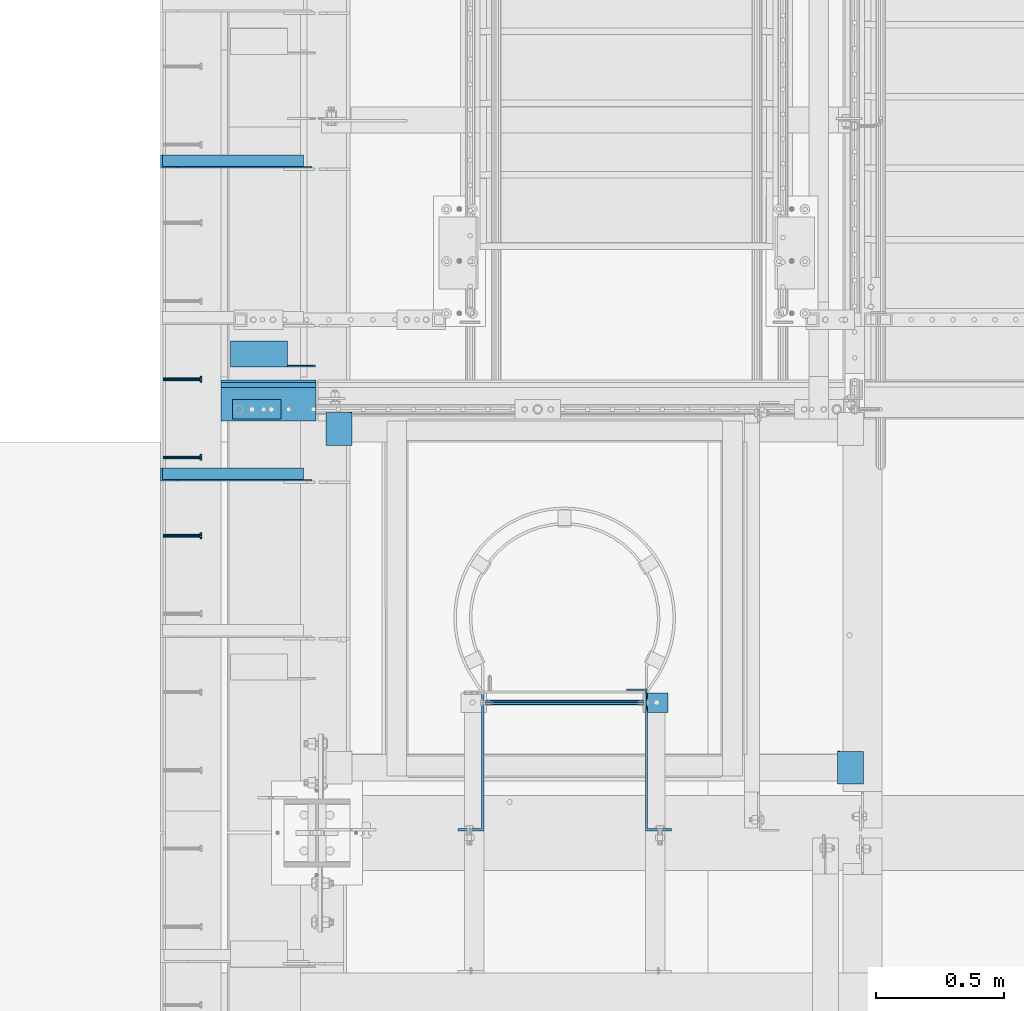
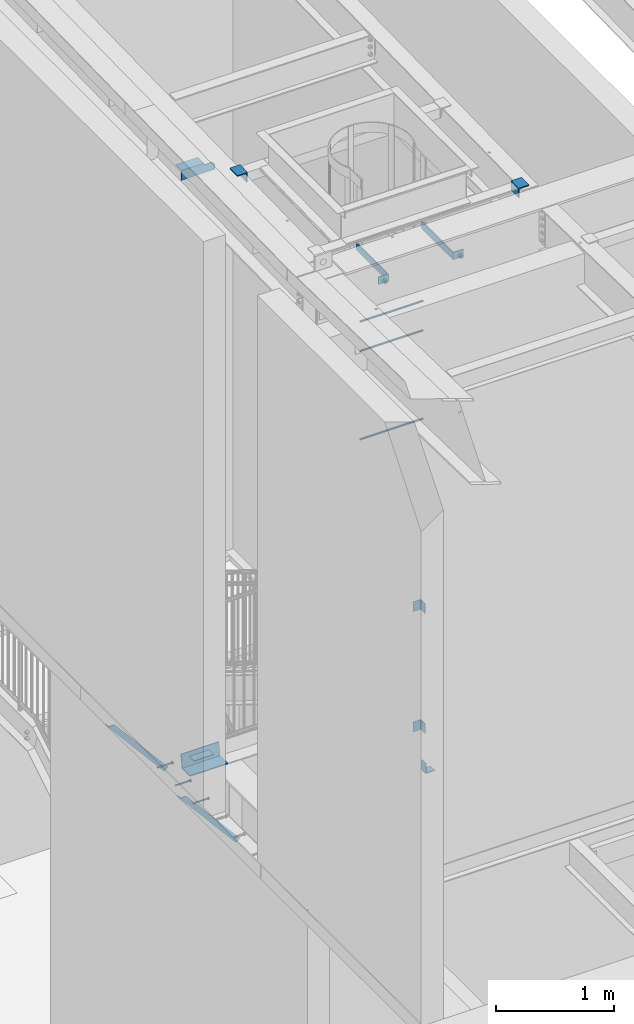
# One storey, part 1256 of 1763: 16 beams, 2 members, 8 elements without a shape of their own.
"""IFC2X3 building model written with IfcOpenShell, lengths in millimetres."""

from ifc_helpers import new_model, si_unit, frame, origin_with_axes, place, context, subcontext, project, spatial, faceted_brep, material, type_object, element, aggregate, save


model = new_model("IFC2X3")

# Units and contexts
model_context = context("Model", 3, precision=1e-05, world=origin_with_axes())
body_context = subcontext(model_context, "Body", "Model", "MODEL_VIEW")
ifc_project = project(units=[si_unit("LENGTHUNIT", "METRE", prefix="MILLI"), si_unit("AREAUNIT", "SQUARE_METRE"), si_unit("VOLUMEUNIT", "CUBIC_METRE"), si_unit("MASSUNIT", "GRAM", prefix="KILO"), si_unit("TIMEUNIT", "SECOND"), si_unit("PLANEANGLEUNIT", "RADIAN"), si_unit("SOLIDANGLEUNIT", "STERADIAN"), si_unit("THERMODYNAMICTEMPERATUREUNIT", "DEGREE_CELSIUS"), si_unit("LUMINOUSINTENSITYUNIT", "LUMEN")], contexts=[model_context])

# Site, building, storey
site_placement = place(None, origin_with_axes())
site = spatial("IfcSite", under=ifc_project, at=site_placement, CompositionType="ELEMENT")
building_placement = place(site_placement, origin_with_axes())
building = spatial("IfcBuilding", under=site, at=building_placement, Name="Undefined", CompositionType="ELEMENT")
storey_placement = place(building_placement, origin_with_axes())
storey = spatial("IfcBuildingStorey", under=building, at=storey_placement, Name="Undefined", CompositionType="ELEMENT", Elevation=0.0)

# Assembly, beam
assembly_1_placement = place(storey_placement, origin_with_axes())
assembly_1 = element("IfcElementAssembly", 1, at=assembly_1_placement, inside=storey, Name="HEADED STUD ANCHOR", AssemblyPlace="NOTDEFINED", PredefinedType="RIGID_FRAME")
ifc_material_1 = material(Name="STEEL/A108")
beam_type_1 = type_object("IfcBeamType", PredefinedType="NOTDEFINED")
beam_1_placement = place(assembly_1_placement, frame((-87975.5122736983, 31181.6750061035, 5268.91250001202), z_axis=(0.0, 0.0, -1.0), x_axis=(1.0, 0.0, 0.0)))
beam_1 = element("IfcBeam", 2, at=beam_1_placement, type_object=beam_type_1, material=ifc_material_1, Name="HEADED STUD ANCHOR", context=body_context, shape_type="Brep", body=[
    faceted_brep([(0.0, -3.1800000667572, 5.5), (0.0, -5.5, 3.1800000667572), (141.732000000002, -5.5, 3.1800000667572), (141.732000000002, -3.1800000667572, 5.5), (0.0, -6.34999999999491, 1.45519152283669e-11), (141.732000000002, -6.34999990463257, 0.0), (0.0, -5.5, -3.1800000667572), (141.732000000002, -5.5, -3.1800000667572), (0.0, -3.1800000667572, -5.5), (141.732000000002, -3.1800000667572, -5.5), (0.0, 0.0, -6.34999990463257), (141.732000000002, 0.0, -6.34999990463257), (0.0, 3.1800000667572, -5.5), (141.732000000002, 3.1800000667572, -5.5), (0.0, 5.5, -3.1800000667572), (141.732000000002, 5.5, -3.1800000667572), (0.0, 6.34999999999491, -2.91038304567337e-11), (141.732000000002, 6.34999990463257, 0.0), (0.0, 5.5, 3.1800000667572), (141.732000000002, 5.5, 3.1800000667572), (0.0, 3.1800000667572, 5.5), (141.732000000002, 3.1800000667572, 5.5), (0.0, 0.0, 6.34999990463257), (141.732000000002, 0.0, 6.34999990463257), (144.780000000001, -10.9899997711182, 6.34999990463257), (144.780000000001, -6.34000015258789, 10.9899997711182), (144.780000000001, -12.6999998092651, 0.0), (144.780000000001, -10.9899997711182, -6.34999990463257), (144.780000000001, -6.34000015258789, -10.9899997711182), (144.780000000001, 0.0, -12.6899995803833), (144.780000000001, 6.34000015258789, -10.9899997711182), (144.780000000001, 10.9899997711182, -6.34999990463257), (144.780000000001, 12.6999998092651, 0.0), (144.780000000001, 10.9899997711182, 6.34999990463257), (144.780000000001, 6.34000015258789, 10.9899997711182), (144.780000000001, 0.0, 12.6899995803833), (152.400000000001, -10.9899997711182, 6.34999990463257), (152.400000000001, -6.34000015258789, 10.9899997711182), (152.400000000001, -12.6999998092651, 0.0), (152.400000000001, -10.9899997711182, -6.34999990463257), (152.400000000001, -6.34000015258789, -10.9899997711182), (152.400000000001, 0.0, -12.6899995803833), (152.400000000001, 6.34000015258789, -10.9899997711182), (152.400000000001, 10.9899997711182, -6.34999990463257), (152.400000000001, 12.6999998092651, 0.0), (152.400000000001, 10.9899997711182, 6.34999990463257), (152.400000000001, 6.34000015258789, 10.9899997711182), (152.400000000001, 0.0, 12.6899995803833)], [[[0, 1, 2, 3]], [[1, 4, 5, 2]], [[4, 6, 7, 5]], [[6, 8, 9, 7]], [[8, 10, 11, 9]], [[10, 12, 13, 11]], [[12, 14, 15, 13]], [[14, 16, 17, 15]], [[16, 18, 19, 17]], [[18, 20, 21, 19]], [[20, 22, 23, 21]], [[22, 0, 3, 23]], [[22, 20, 18, 16, 14, 12, 10, 8, 6, 4, 1, 0]], [[3, 2, 24, 25]], [[2, 5, 26, 24]], [[5, 7, 27, 26]], [[7, 9, 28, 27]], [[9, 11, 29, 28]], [[11, 13, 30, 29]], [[13, 15, 31, 30]], [[15, 17, 32, 31]], [[17, 19, 33, 32]], [[19, 21, 34, 33]], [[21, 23, 35, 34]], [[23, 3, 25, 35]], [[25, 24, 36, 37]], [[24, 26, 38, 36]], [[26, 27, 39, 38]], [[27, 28, 40, 39]], [[28, 29, 41, 40]], [[29, 30, 42, 41]], [[30, 31, 43, 42]], [[31, 32, 44, 43]], [[32, 33, 45, 44]], [[33, 34, 46, 45]], [[34, 35, 47, 46]], [[35, 25, 37, 47]], [[38, 39, 40, 41, 42, 43, 44, 45, 46, 47, 37, 36]]]),
])
aggregate(assembly_1, [beam_1])

assembly_2_placement = place(storey_placement, origin_with_axes())
assembly_2 = element("IfcElementAssembly", 3, at=assembly_2_placement, inside=storey, Name="HEADED STUD ANCHOR", AssemblyPlace="NOTDEFINED", PredefinedType="RIGID_FRAME")
beam_2_placement = place(assembly_2_placement, frame((-87975.5122736983, 31486.4750061035, 5268.91250001202), z_axis=(0.0, 0.0, -1.0), x_axis=(1.0, 0.0, 0.0)))
beam_2 = element("IfcBeam", 4, at=beam_2_placement, type_object=beam_type_1, material=ifc_material_1, Name="HEADED STUD ANCHOR", context=body_context, shape_type="Brep", body=[
    faceted_brep([(0.0, -3.1800000667572, 5.5), (0.0, -5.5, 3.1800000667572), (141.732000000002, -5.5, 3.1800000667572), (141.732000000002, -3.1800000667572, 5.5), (0.0, -6.34999999999491, 1.45519152283669e-11), (141.732000000002, -6.34999990463257, 0.0), (0.0, -5.5, -3.1800000667572), (141.732000000002, -5.5, -3.1800000667572), (0.0, -3.1800000667572, -5.5), (141.732000000002, -3.1800000667572, -5.5), (0.0, 0.0, -6.34999990463257), (141.732000000002, 0.0, -6.34999990463257), (0.0, 3.1800000667572, -5.5), (141.732000000002, 3.1800000667572, -5.5), (0.0, 5.5, -3.1800000667572), (141.732000000002, 5.5, -3.1800000667572), (0.0, 6.34999999999491, -2.91038304567337e-11), (141.732000000002, 6.34999990463257, 0.0), (0.0, 5.5, 3.1800000667572), (141.732000000002, 5.5, 3.1800000667572), (0.0, 3.1800000667572, 5.5), (141.732000000002, 3.1800000667572, 5.5), (0.0, 0.0, 6.34999990463257), (141.732000000002, 0.0, 6.34999990463257), (144.780000000001, -10.9899997711182, 6.34999990463257), (144.780000000001, -6.34000015258789, 10.9899997711182), (144.780000000001, -12.6999998092651, 0.0), (144.780000000001, -10.9899997711182, -6.34999990463257), (144.780000000001, -6.34000015258789, -10.9899997711182), (144.780000000001, 0.0, -12.6899995803833), (144.780000000001, 6.34000015258789, -10.9899997711182), (144.780000000001, 10.9899997711182, -6.34999990463257), (144.780000000001, 12.6999998092651, 0.0), (144.780000000001, 10.9899997711182, 6.34999990463257), (144.780000000001, 6.34000015258789, 10.9899997711182), (144.780000000001, 0.0, 12.6899995803833), (152.400000000001, -10.9899997711182, 6.34999990463257), (152.400000000001, -6.34000015258789, 10.9899997711182), (152.400000000001, -12.6999998092651, 0.0), (152.400000000001, -10.9899997711182, -6.34999990463257), (152.400000000001, -6.34000015258789, -10.9899997711182), (152.400000000001, 0.0, -12.6899995803833), (152.400000000001, 6.34000015258789, -10.9899997711182), (152.400000000001, 10.9899997711182, -6.34999990463257), (152.400000000001, 12.6999998092651, 0.0), (152.400000000001, 10.9899997711182, 6.34999990463257), (152.400000000001, 6.34000015258789, 10.9899997711182), (152.400000000001, 0.0, 12.6899995803833)], [[[0, 1, 2, 3]], [[1, 4, 5, 2]], [[4, 6, 7, 5]], [[6, 8, 9, 7]], [[8, 10, 11, 9]], [[10, 12, 13, 11]], [[12, 14, 15, 13]], [[14, 16, 17, 15]], [[16, 18, 19, 17]], [[18, 20, 21, 19]], [[20, 22, 23, 21]], [[22, 0, 3, 23]], [[22, 20, 18, 16, 14, 12, 10, 8, 6, 4, 1, 0]], [[3, 2, 24, 25]], [[2, 5, 26, 24]], [[5, 7, 27, 26]], [[7, 9, 28, 27]], [[9, 11, 29, 28]], [[11, 13, 30, 29]], [[13, 15, 31, 30]], [[15, 17, 32, 31]], [[17, 19, 33, 32]], [[19, 21, 34, 33]], [[21, 23, 35, 34]], [[23, 3, 25, 35]], [[25, 24, 36, 37]], [[24, 26, 38, 36]], [[26, 27, 39, 38]], [[27, 28, 40, 39]], [[28, 29, 41, 40]], [[29, 30, 42, 41]], [[30, 31, 43, 42]], [[31, 32, 44, 43]], [[32, 33, 45, 44]], [[33, 34, 46, 45]], [[34, 35, 47, 46]], [[35, 25, 37, 47]], [[38, 39, 40, 41, 42, 43, 44, 45, 46, 47, 37, 36]]]),
])
aggregate(assembly_2, [beam_2])

assembly_3_placement = place(storey_placement, origin_with_axes())
assembly_3 = element("IfcElementAssembly", 5, at=assembly_3_placement, inside=storey, Name="HEADED STUD ANCHOR", AssemblyPlace="NOTDEFINED", PredefinedType="RIGID_FRAME")
beam_3_placement = place(assembly_3_placement, frame((-87975.5122736983, 31791.2750061035, 5268.91250001202), z_axis=(0.0, 0.0, -1.0), x_axis=(1.0, 0.0, 0.0)))
beam_3 = element("IfcBeam", 6, at=beam_3_placement, type_object=beam_type_1, material=ifc_material_1, Name="HEADED STUD ANCHOR", context=body_context, shape_type="Brep", body=[
    faceted_brep([(0.0, -3.1800000667572, 5.5), (0.0, -5.5, 3.1800000667572), (141.732000000002, -5.5, 3.1800000667572), (141.732000000002, -3.1800000667572, 5.5), (0.0, -6.34999999999491, 1.45519152283669e-11), (141.732000000002, -6.34999990463257, 0.0), (0.0, -5.5, -3.1800000667572), (141.732000000002, -5.5, -3.1800000667572), (0.0, -3.1800000667572, -5.5), (141.732000000002, -3.1800000667572, -5.5), (0.0, 0.0, -6.34999990463257), (141.732000000002, 0.0, -6.34999990463257), (0.0, 3.1800000667572, -5.5), (141.732000000002, 3.1800000667572, -5.5), (0.0, 5.5, -3.1800000667572), (141.732000000002, 5.5, -3.1800000667572), (0.0, 6.34999999999491, -2.91038304567337e-11), (141.732000000002, 6.34999990463257, 0.0), (0.0, 5.5, 3.1800000667572), (141.732000000002, 5.5, 3.1800000667572), (0.0, 3.1800000667572, 5.5), (141.732000000002, 3.1800000667572, 5.5), (0.0, 0.0, 6.34999990463257), (141.732000000002, 0.0, 6.34999990463257), (144.780000000001, -10.9899997711182, 6.34999990463257), (144.780000000001, -6.34000015258789, 10.9899997711182), (144.780000000001, -12.6999998092651, 0.0), (144.780000000001, -10.9899997711182, -6.34999990463257), (144.780000000001, -6.34000015258789, -10.9899997711182), (144.780000000001, 0.0, -12.6899995803833), (144.780000000001, 6.34000015258789, -10.9899997711182), (144.780000000001, 10.9899997711182, -6.34999990463257), (144.780000000001, 12.6999998092651, 0.0), (144.780000000001, 10.9899997711182, 6.34999990463257), (144.780000000001, 6.34000015258789, 10.9899997711182), (144.780000000001, 0.0, 12.6899995803833), (152.400000000001, -10.9899997711182, 6.34999990463257), (152.400000000001, -6.34000015258789, 10.9899997711182), (152.400000000001, -12.6999998092651, 0.0), (152.400000000001, -10.9899997711182, -6.34999990463257), (152.400000000001, -6.34000015258789, -10.9899997711182), (152.400000000001, 0.0, -12.6899995803833), (152.400000000001, 6.34000015258789, -10.9899997711182), (152.400000000001, 10.9899997711182, -6.34999990463257), (152.400000000001, 12.6999998092651, 0.0), (152.400000000001, 10.9899997711182, 6.34999990463257), (152.400000000001, 6.34000015258789, 10.9899997711182), (152.400000000001, 0.0, 12.6899995803833)], [[[0, 1, 2, 3]], [[1, 4, 5, 2]], [[4, 6, 7, 5]], [[6, 8, 9, 7]], [[8, 10, 11, 9]], [[10, 12, 13, 11]], [[12, 14, 15, 13]], [[14, 16, 17, 15]], [[16, 18, 19, 17]], [[18, 20, 21, 19]], [[20, 22, 23, 21]], [[22, 0, 3, 23]], [[22, 20, 18, 16, 14, 12, 10, 8, 6, 4, 1, 0]], [[3, 2, 24, 25]], [[2, 5, 26, 24]], [[5, 7, 27, 26]], [[7, 9, 28, 27]], [[9, 11, 29, 28]], [[11, 13, 30, 29]], [[13, 15, 31, 30]], [[15, 17, 32, 31]], [[17, 19, 33, 32]], [[19, 21, 34, 33]], [[21, 23, 35, 34]], [[23, 3, 25, 35]], [[25, 24, 36, 37]], [[24, 26, 38, 36]], [[26, 27, 39, 38]], [[27, 28, 40, 39]], [[28, 29, 41, 40]], [[29, 30, 42, 41]], [[30, 31, 43, 42]], [[31, 32, 44, 43]], [[32, 33, 45, 44]], [[33, 34, 46, 45]], [[34, 35, 47, 46]], [[35, 25, 37, 47]], [[38, 39, 40, 41, 42, 43, 44, 45, 46, 47, 37, 36]]]),
])
aggregate(assembly_3, [beam_3])

# Assembly, members
assembly_4_placement = place(storey_placement, origin_with_axes())
assembly_4 = element("IfcElementAssembly", 7, at=assembly_4_placement, inside=storey, Name="BEAM", AssemblyPlace="NOTDEFINED", PredefinedType="RIGID_FRAME")
ifc_material_2 = material(Name="STEEL/A36")
member_type = type_object("IfcMemberType", Name="L2X2X1/4", PredefinedType="NOTDEFINED")
member_1_placement = place(assembly_4_placement, frame((-87414.1929584935, 32639.0, 4557.35349338836), z_axis=(0.764183480307171, 0.0, 0.644998921259268), x_axis=(-0.644998921259266, 0.0, 0.764183480307173)))
member_1 = element("IfcMember", 8, at=member_1_placement, type_object=member_type, material=ifc_material_2, Name="ANGLE", ObjectType="L2X2X1/4", context=body_context, shape_type="Brep", body=[
    faceted_brep([(-1.45519152283669e-11, 25.4000000000015, -25.3999999999869), (1.45519152283669e-11, 25.4000000000015, 25.3999999999796), (812.060911532491, 25.4000000000015, 25.400000001966), (854.937976763787, 25.4000000000015, -25.3999999979424), (1.45519152283669e-11, 19.0499999999993, 25.3999999999796), (812.060911532491, 19.0500000000029, 25.400000001966), (-7.27595761418343e-12, 19.0499999999993, -19.0499999999956), (849.578343609872, 19.0500000000029, -19.0499999979511), (-7.27595761418343e-12, -25.4000000000015, -19.0499999999956), (849.578343609872, -25.4000000000015, -19.0499999979511), (-1.45519152283669e-11, -25.4000000000015, -25.3999999999869), (854.937976763787, -25.4000000000015, -25.3999999979424)], [[[0, 1, 2, 3]], [[1, 4, 5, 2]], [[4, 6, 7, 5]], [[6, 8, 9, 7]], [[8, 10, 11, 9]], [[10, 0, 3, 11]], [[5, 7, 9, 11, 3, 2]], [[10, 8, 6, 4, 1, 0]]]),
])
member_2_placement = place(assembly_4_placement, frame((-87414.1929584935, 31419.8, 4557.35349338836), z_axis=(0.764183480307171, 0.0, 0.644998921259268), x_axis=(-0.644998921259266, 0.0, 0.764183480307173)))
member_2 = element("IfcMember", 9, at=member_2_placement, type_object=member_type, material=ifc_material_2, Name="ANGLE", ObjectType="L2X2X1/4", context=body_context, shape_type="Brep", body=[
    faceted_brep([(-1.45519152283669e-11, 25.4000000000015, -25.3999999999869), (1.45519152283669e-11, 25.4000000000015, 25.3999999999796), (812.060911532491, 25.4000000000015, 25.400000001966), (854.937976763787, 25.4000000000015, -25.3999999979424), (1.45519152283669e-11, 19.0499999999993, 25.3999999999796), (812.060911532491, 19.0500000000029, 25.400000001966), (-7.27595761418343e-12, 19.0499999999993, -19.0499999999956), (849.578343609872, 19.0500000000029, -19.0499999979511), (-7.27595761418343e-12, -25.4000000000015, -19.0499999999956), (849.578343609872, -25.4000000000015, -19.0499999979511), (-1.45519152283669e-11, -25.4000000000015, -25.3999999999869), (854.937976763787, -25.4000000000015, -25.3999999979424)], [[[0, 1, 2, 3]], [[1, 4, 5, 2]], [[4, 6, 7, 5]], [[6, 8, 9, 7]], [[8, 10, 11, 9]], [[10, 0, 3, 11]], [[5, 7, 9, 11, 3, 2]], [[10, 8, 6, 4, 1, 0]]]),
])

# Assembly, beam
assembly_5_placement = place(storey_placement, origin_with_axes())
assembly_5 = element("IfcElementAssembly", 10, at=assembly_5_placement, inside=storey, Name="BEAM", AssemblyPlace="NOTDEFINED", PredefinedType="RIGID_FRAME")
beam_type_2 = type_object("IfcBeamType", Name="L4X4X1/4", PredefinedType="NOTDEFINED")
beam_4_placement = place(assembly_5_placement, frame((-87711.9872706466, 31890.376306879, 11278.1286374879), z_axis=(0.0, 0.0206852279954837, -0.999786037781472), x_axis=(1.0, 0.0, 0.0)))
beam_4 = element("IfcBeam", 11, at=beam_4_placement, type_object=beam_type_2, material=ifc_material_2, Name="BRACE", ObjectType="L4X4X1/4", context=body_context, shape_type="Brep", body=[
    faceted_brep([(220.662761923406, 44.4500000001208, -44.4499999999807), (220.662761962012, -50.800000000163, -44.4499999999553), (220.66276795695, -50.800000000163, -50.7999999999502), (220.662767915564, 50.8000000001339, -50.7999999999774), (220.662751535681, 50.8000000001339, -33.3786578752915), (220.662751538272, 44.4500000001208, -33.3786578752897), (299.243730570859, 44.4500000001135, -33.3375021376705), (299.243730570859, 50.8000000001339, -33.3375021376723), (2.11002770811319e-10, -50.8000000000357, -50.799999999952), (1.96450855582952e-10, -50.8000000000338, -44.4499999999534), (-2.18278728425503e-11, 44.4500000000007, -44.450000000048), (-1.81898940354586e-10, 44.4500000000371, 50.7999999999374), (-1.96450855582952e-10, 50.8000000000393, 50.7999999999374), (-3.63797880709171e-11, 50.8000000000011, -50.8000000000538), (330.993731689443, 44.4500000000007, 50.7999999999993), (330.993731689443, 50.7999999999993, 50.7999999999993), (330.993730570859, 44.4500000001281, -1.58750213774329), (330.993746948254, 50.8000000001412, -1.5875021377451)], [[[0, 1, 2, 3, 4, 5]], [[6, 5, 4, 7]], [[8, 9, 10, 11, 12, 13]], [[12, 11, 14, 15]], [[15, 14, 16, 17]], [[17, 16, 6, 7]], [[3, 13, 12, 15, 17, 7, 4]], [[8, 13, 3, 2]], [[9, 8, 2, 1]], [[10, 9, 1, 0]], [[16, 14, 11, 10, 0, 5, 6]]]),
])
aggregate(assembly_5, [beam_4])

# Assembly, beams
assembly_6_placement = place(storey_placement, origin_with_axes())
assembly_6 = element("IfcElementAssembly", 12, at=assembly_6_placement, inside=storey, Name="ANGLE", AssemblyPlace="NOTDEFINED", PredefinedType="RIGID_FRAME")
beam_type_3 = type_object("IfcBeamType", Name="L4X4X3/8", PredefinedType="NOTDEFINED")
beam_5_placement = place(assembly_6_placement, frame((-85296.5734375, 30341.7077508276, 11255.2535212873), z_axis=(0.0, 0.0209829029927459, -0.999779834654609), x_axis=(0.0, -0.999779834654609, -0.0209829029927513)))
beam_5 = element("IfcBeam", 13, at=beam_5_placement, type_object=beam_type_3, material=ifc_material_2, Name="ANGLE", ObjectType="L4X4X3/8", context=body_context, shape_type="Brep", body=[
    faceted_brep([(-3.63797880709171e-11, 50.8000000000011, -50.8000000000538), (-1.96450855582952e-10, 50.8000000000393, 50.7999999999374), (127.680357143057, 50.8000000000029, 50.8000000000775), (127.680357142966, 50.8000000000029, -50.7999999998556), (0.0, 41.2749999999996, 50.7999999999993), (127.680357143057, 41.2749999999942, 50.8000000000775), (0.0, 41.2749999999996, -41.2750000000015), (127.680357142981, 41.2749999999942, -41.2749999998596), (0.0, -50.7999999999993, -41.2750000000015), (127.680357142981, -50.8000000000029, -41.2749999998596), (2.11002770811319e-10, -50.8000000000357, -50.799999999952), (127.680357142966, -50.8000000000029, -50.7999999998556)], [[[0, 1, 2, 3]], [[1, 4, 5, 2]], [[4, 6, 7, 5]], [[6, 8, 9, 7]], [[8, 10, 11, 9]], [[10, 0, 3, 11]], [[5, 7, 9, 11, 3, 2]], [[10, 8, 6, 4, 1, 0]]]),
])
beam_6_placement = place(assembly_6_placement, frame((-87289.6796875, 31534.5647100958, 11280.2886345726), z_axis=(0.0, 0.0209829029927459, -0.999779834654609), x_axis=(0.0, 0.999779834654609, 0.0209829029927513)))
beam_6 = element("IfcBeam", 14, at=beam_6_placement, type_object=beam_type_3, material=ifc_material_2, Name="ANGLE", ObjectType="L4X4X3/8", context=body_context, shape_type="Brep", body=[
    faceted_brep([(-3.63797880709171e-11, 50.8000000000011, -50.8000000000538), (-1.96450855582952e-10, 50.8000000000393, 50.7999999999374), (127.680357143057, 50.8000000000029, 50.8000000000775), (127.680357142966, 50.8000000000029, -50.7999999998556), (0.0, 41.2749999999996, 50.7999999999993), (127.680357143057, 41.2749999999942, 50.8000000000775), (0.0, 41.2749999999996, -41.2750000000015), (127.680357142981, 41.2749999999942, -41.2749999998596), (0.0, -50.7999999999993, -41.2750000000015), (127.680357142981, -50.8000000000029, -41.2749999998596), (2.11002770811319e-10, -50.8000000000357, -50.799999999952), (127.680357142966, -50.8000000000029, -50.7999999998556)], [[[0, 1, 2, 3]], [[1, 4, 5, 2]], [[4, 6, 7, 5]], [[6, 8, 9, 7]], [[8, 10, 11, 9]], [[10, 0, 3, 11]], [[5, 7, 9, 11, 3, 2]], [[10, 8, 6, 4, 1, 0]]]),
])
aggregate(assembly_6, [beam_5, beam_6])

# Assembly, beam
assembly_7_placement = place(storey_placement, origin_with_axes())
assembly_7 = element("IfcElementAssembly", 15, at=assembly_7_placement, inside=storey, Name="LADDER", AssemblyPlace="NOTDEFINED", PredefinedType="RIGID_FRAME")
beam_type_4 = type_object("IfcBeamType", PredefinedType="NOTDEFINED")
beam_7_placement = place(assembly_7_placement, frame((-86006.9472948628, 30530.7999938243, 5337.17499999941), z_axis=(0.0, 1.0, 0.0), x_axis=(-1.0, 0.0, 0.0)))
beam_7 = element("IfcBeam", 16, at=beam_7_placement, type_object=beam_type_4, material=ifc_material_2, Name="BENT_PLATE", context=body_context, shape_type="Brep", body=[
    faceted_brep([(0.0, -3.17500000000018, -38.0999999999985), (0.0, -3.17500000000018, 38.0999999999985), (0.0, 3.17500000000018, 38.0999999999985), (0.0, 3.17500000000018, -38.0999999999985), (82.5500015258731, 3.17500000000655, 38.0999999999985), (82.5500015258731, 3.17500000000655, -38.0999999999985), (88.9000015258789, -3.17499999999291, -38.0999999999985), (88.9000015258789, -3.17499999999291, 38.0999999999985), (82.5500015258731, 98.4249984741209, 38.0999999999985), (82.5500015258731, 98.4249984741209, -38.0999999999985), (88.9000015258789, 98.4249984741209, 38.0999999999985), (88.9000015258789, 98.4249984741209, -38.0999999999985)], [[[0, 1, 2, 3]], [[3, 2, 4, 5]], [[1, 0, 6, 7]], [[5, 4, 8, 9]], [[4, 2, 1, 7, 10, 8]], [[7, 6, 11, 10]], [[6, 0, 3, 5, 9, 11]], [[10, 11, 9, 8]]]),
])

assembly_8_placement = place(storey_placement, origin_with_axes())
assembly_8 = element("IfcElementAssembly", 17, at=assembly_8_placement, inside=storey, Name="RAIL", AssemblyPlace="NOTDEFINED", PredefinedType="RIGID_FRAME")
beam_8_placement = place(assembly_8_placement, frame((-87610.3872736986, 31635.699999617, 5337.175), z_axis=(-1.0, 0.0, 0.0), x_axis=(0.0, 1.0, 0.0)))
beam_8 = element("IfcBeam", 18, at=beam_8_placement, type_object=beam_type_4, material=ifc_material_2, context=body_context, shape_type="Brep", body=[
    faceted_brep([(0.0, 3.17500000000001, -95.25), (0.0, 3.17499999999927, 95.25), (76.1999968561649, 3.17499999984284, 95.25), (76.1999999999971, 3.17500000000001, -95.25), (0.0, -3.17499999999927, 95.25), (76.1999970403122, -3.17500000015571, 95.25), (0.0, -3.17500000000001, -95.25), (76.1999999999971, -3.17500000000001, -95.25)], [[[0, 1, 2, 3]], [[1, 4, 5, 2]], [[4, 6, 7, 5]], [[6, 0, 3, 7]], [[5, 7, 3, 2]], [[6, 4, 1, 0]]]),
])
aggregate(assembly_8, [beam_8])

# Beam
beam_type_5 = type_object("IfcBeamType", PredefinedType="NOTDEFINED")
beam_9_placement = place(assembly_7_placement, frame((-86100.6747736991, 30530.8, 8991.6), z_axis=(0.0, -1.0, 0.0), x_axis=(-1.0, 0.0, 0.0)))
beam_9 = element("IfcBeam", 19, at=beam_9_placement, type_object=beam_type_5, material=ifc_material_2, Name="RUNG", context=body_context, shape_type="Brep", body=[
    faceted_brep([(0.0, -9.52500000000146, 0.0), (0.0, -6.73519209080041, -6.73519209079677), (619.125, -6.73519209080223, -6.73519209080041), (619.125, -9.52499999999964, 0.0), (0.0, 0.0, -9.52499999999418), (619.125, 0.0, -9.52500000000146), (0.0, 6.73519209080041, -6.73519209079677), (619.125, 6.73519209080223, -6.73519209080041), (0.0, 9.52500000000146, 0.0), (619.125, 9.52499999999964, 0.0), (0.0, 6.73519209080041, 6.73519209079677), (619.125, 6.73519209080223, 6.73519209080041), (0.0, 0.0, 9.52499999999418), (619.125, 0.0, 9.52500000000146), (0.0, -6.73519209080041, 6.73519209079677), (619.125, -6.73519209080223, 6.73519209080041)], [[[0, 1, 2, 3]], [[1, 4, 5, 2]], [[4, 6, 7, 5]], [[6, 8, 9, 7]], [[8, 10, 11, 9]], [[10, 12, 13, 11]], [[12, 14, 15, 13]], [[14, 0, 3, 15]], [[5, 7, 9, 11, 13, 15, 3, 2]], [[14, 12, 10, 8, 6, 4, 1, 0]]]),
])

beam_10_placement = place(assembly_7_placement, frame((-86100.6747736991, 30530.8, 9906.0), z_axis=(0.0, -1.0, 0.0), x_axis=(-1.0, 0.0, 0.0)))
beam_10 = element("IfcBeam", 20, at=beam_10_placement, type_object=beam_type_5, material=ifc_material_2, Name="RUNG", context=body_context, shape_type="Brep", body=[
    faceted_brep([(0.0, -9.52500000000146, 0.0), (0.0, -6.73519209080041, -6.73519209079677), (619.125, -6.73519209080223, -6.73519209080041), (619.125, -9.52499999999964, 0.0), (0.0, 0.0, -9.52499999999418), (619.125, 0.0, -9.52500000000146), (0.0, 6.73519209080041, -6.73519209079677), (619.125, 6.73519209080223, -6.73519209080041), (0.0, 9.52500000000146, 0.0), (619.125, 9.52499999999964, 0.0), (0.0, 6.73519209080041, 6.73519209079677), (619.125, 6.73519209080223, 6.73519209080041), (0.0, 0.0, 9.52499999999418), (619.125, 0.0, 9.52500000000146), (0.0, -6.73519209080041, 6.73519209079677), (619.125, -6.73519209080223, 6.73519209080041)], [[[0, 1, 2, 3]], [[1, 4, 5, 2]], [[4, 6, 7, 5]], [[6, 8, 9, 7]], [[8, 10, 11, 9]], [[10, 12, 13, 11]], [[12, 14, 15, 13]], [[14, 0, 3, 15]], [[5, 7, 9, 11, 13, 15, 3, 2]], [[14, 12, 10, 8, 6, 4, 1, 0]]]),
])

beam_11_placement = place(assembly_7_placement, frame((-86100.6747736991, 30530.8, 10210.8), z_axis=(0.0, -1.0, 0.0), x_axis=(-1.0, 0.0, 0.0)))
beam_11 = element("IfcBeam", 21, at=beam_11_placement, type_object=beam_type_5, material=ifc_material_2, Name="RUNG", context=body_context, shape_type="Brep", body=[
    faceted_brep([(0.0, -9.52500000000146, 0.0), (0.0, -6.73519209080041, -6.73519209079677), (619.125, -6.73519209080223, -6.73519209080041), (619.125, -9.52499999999964, 0.0), (0.0, 0.0, -9.52499999999418), (619.125, 0.0, -9.52500000000146), (0.0, 6.73519209080041, -6.73519209079677), (619.125, 6.73519209080223, -6.73519209080041), (0.0, 9.52500000000146, 0.0), (619.125, 9.52499999999964, 0.0), (0.0, 6.73519209080041, 6.73519209079677), (619.125, 6.73519209080223, 6.73519209080041), (0.0, 0.0, 9.52499999999418), (619.125, 0.0, 9.52500000000146), (0.0, -6.73519209080041, 6.73519209079677), (619.125, -6.73519209080223, 6.73519209080041)], [[[0, 1, 2, 3]], [[1, 4, 5, 2]], [[4, 6, 7, 5]], [[6, 8, 9, 7]], [[8, 10, 11, 9]], [[10, 12, 13, 11]], [[12, 14, 15, 13]], [[14, 0, 3, 15]], [[5, 7, 9, 11, 13, 15, 3, 2]], [[14, 12, 10, 8, 6, 4, 1, 0]]]),
])

beam_type_6 = type_object("IfcBeamType", PredefinedType="NOTDEFINED")
beam_12_placement = place(assembly_7_placement, frame((-86093.836192462, 30501.431, 7035.8001228935), z_axis=(0.0, 0.0, 1.0), x_axis=(0.0, 1.0, 0.0)))
beam_12 = element("IfcBeam", 22, at=beam_12_placement, type_object=beam_type_6, material=ifc_material_2, Name="3X3 BLANK BUTT HINGE", context=body_context, shape_type="Brep", body=[
    faceted_brep([(76.9939999999988, 76.161438701296, -50.8000000000002), (76.9939999999988, 76.161438701296, 50.8000000000002), (81.7560000000012, 76.161438701296, 50.8000000000002), (81.7560000000012, 76.161438701296, -50.8000000000002), (81.7560000000012, 3.77625750798325, -50.8294562948668), (81.7560000000012, 3.77625750798325, 50.7705437051445), (79.375, 4.76249999999709, -50.8294562948668), (76.9939999999988, 3.77625750798325, -50.8294562948668), (76.9939999999988, 3.77625750798325, 50.7705437051445), (79.375, 4.76249999999709, 50.7705437051445), (0.0, -2.38099999999395, -50.8000000000002), (0.0, -2.38099999999395, 50.8000000000002), (0.0, 2.38099999999395, 50.8000000000002), (0.0, 2.38099999999395, -50.8000000000002), (74.6124999999993, 0.0, 50.7705437051445), (75.5987424920095, 2.38099999999395, 50.7705437051445), (75.5987424920095, -2.38099999999395, 50.7705437051445), (75.5987424920095, 2.38099999999395, -50.8294562948668), (75.5987424920095, -2.38099999999395, -50.8000000000002), (74.6124999999993, 0.0, -50.8294562948668), (84.1375000000007, 0.0, -50.8294562948668), (82.742596045402, 3.36759604539839, -50.8294562948668), (82.742596045402, 3.36759604539839, 50.7705437051445), (84.1375000000007, 0.0, 50.7705437051445), (82.742596045402, -3.36759604539839, -50.8294562948668), (82.742596045402, -3.36759604539839, 50.7705437051445), (79.375, -4.76249999999709, -50.8294562948668), (79.375, -4.76249999999709, 50.7705437051445), (76.007403954598, -3.36759604539839, -50.8294562948668), (76.007403954598, -3.36759604539839, 50.7705437051445), (76.007403954598, 3.36759604539839, 50.7705437051445), (76.007403954598, 3.36759604539839, -50.8294562948668)], [[[0, 1, 2, 3]], [[4, 3, 2, 5]], [[6, 7, 0, 3, 4]], [[8, 1, 0, 7]], [[9, 5, 2, 1, 8]], [[10, 11, 12, 13]], [[14, 15, 12, 11, 16]], [[17, 13, 12, 15]], [[18, 10, 13, 17, 19]], [[16, 11, 10, 18]], [[20, 21, 22, 23]], [[24, 20, 23, 25]], [[26, 24, 25, 27]], [[28, 26, 27, 29]], [[28, 29, 16, 18]], [[30, 31, 17, 15]], [[31, 30, 8, 7]], [[6, 4, 21, 20, 24, 26, 28, 18, 19, 17, 31, 7]], [[22, 21, 4, 5]], [[30, 15, 14, 16, 29, 27, 25, 23, 22, 5, 9, 8]]]),
])

beam_13_placement = place(assembly_7_placement, frame((-86093.5312736991, 30501.431, 5791.19999389648), z_axis=(0.0, 0.0, 1.0), x_axis=(0.0, 1.0, 0.0)))
beam_13 = element("IfcBeam", 23, at=beam_13_placement, type_object=beam_type_6, material=ifc_material_2, Name="3X3 BLANK BUTT HINGE", context=body_context, shape_type="Brep", body=[
    faceted_brep([(76.9939999999988, 76.161438701296, -50.8000000000002), (76.9939999999988, 76.161438701296, 50.8000000000002), (81.7560000000012, 76.161438701296, 50.8000000000002), (81.7560000000012, 76.161438701296, -50.8000000000002), (81.7560000000012, 3.77625750798325, -50.8294562948668), (81.7560000000012, 3.77625750798325, 50.7705437051445), (79.375, 4.76249999999709, -50.8294562948668), (76.9939999999988, 3.77625750798325, -50.8294562948668), (76.9939999999988, 3.77625750798325, 50.7705437051445), (79.375, 4.76249999999709, 50.7705437051445), (0.0, -2.38099999999395, -50.8000000000002), (0.0, -2.38099999999395, 50.8000000000002), (0.0, 2.38099999999395, 50.8000000000002), (0.0, 2.38099999999395, -50.8000000000002), (74.6124999999993, 0.0, 50.7705437051445), (75.5987424920095, 2.38099999999395, 50.7705437051445), (75.5987424920095, -2.38099999999395, 50.7705437051445), (75.5987424920095, 2.38099999999395, -50.8294562948668), (75.5987424920095, -2.38099999999395, -50.8000000000002), (74.6124999999993, 0.0, -50.8294562948668), (84.1375000000007, 0.0, -50.8294562948668), (82.742596045402, 3.36759604539839, -50.8294562948668), (82.742596045402, 3.36759604539839, 50.7705437051445), (84.1375000000007, 0.0, 50.7705437051445), (82.742596045402, -3.36759604539839, -50.8294562948668), (82.742596045402, -3.36759604539839, 50.7705437051445), (79.375, -4.76249999999709, -50.8294562948668), (79.375, -4.76249999999709, 50.7705437051445), (76.007403954598, -3.36759604539839, -50.8294562948668), (76.007403954598, -3.36759604539839, 50.7705437051445), (76.007403954598, 3.36759604539839, 50.7705437051445), (76.007403954598, 3.36759604539839, -50.8294562948668)], [[[0, 1, 2, 3]], [[4, 3, 2, 5]], [[6, 7, 0, 3, 4]], [[8, 1, 0, 7]], [[9, 5, 2, 1, 8]], [[10, 11, 12, 13]], [[14, 15, 12, 11, 16]], [[17, 13, 12, 15]], [[18, 10, 13, 17, 19]], [[16, 11, 10, 18]], [[20, 21, 22, 23]], [[24, 20, 23, 25]], [[26, 24, 25, 27]], [[28, 26, 27, 29]], [[28, 29, 16, 18]], [[30, 31, 17, 15]], [[31, 30, 8, 7]], [[6, 4, 21, 20, 24, 26, 28, 18, 19, 17, 31, 7]], [[22, 21, 4, 5]], [[30, 15, 14, 16, 29, 27, 25, 23, 22, 5, 9, 8]]]),
])

beam_type_7 = type_object("IfcBeamType", PredefinedType="NOTDEFINED")
beam_14_placement = place(assembly_7_placement, frame((-86729.3249669171, 30568.9000061422, 10972.8000000621), z_axis=(0.0, 0.0, 1.0), x_axis=(0.0, -1.0, 0.0)))
beam_14 = element("IfcBeam", 24, at=beam_14_placement, type_object=beam_type_7, material=ifc_material_2, Name="LADDER", context=body_context, shape_type="Brep", body=[
    faceted_brep([(0.0, -4.76249999999709, -38.1000000000004), (0.0, -4.76249999999709, 38.1000000000004), (0.0, 4.76249999999709, 38.1000000000004), (0.0, 4.76249999999709, -38.1000000000004), (538.9562377929, 4.76250000002619, 38.1000000000004), (538.9562377929, 4.76250000002619, -38.1000000000004), (529.431237792898, -4.76249999996799, -38.1000000000004), (529.431237792898, -4.76249999996799, 38.1000000000004), (538.9562377929, -96.8374984741968, 38.1000000000004), (538.9562377929, -96.8374984741968, -38.1000000000004), (529.431237792898, -96.8374984741968, 38.1000000000004), (529.431237792898, -96.8374984741968, -38.1000000000004)], [[[0, 1, 2, 3]], [[3, 2, 4, 5]], [[1, 0, 6, 7]], [[5, 4, 8, 9]], [[4, 2, 1, 7, 10, 8]], [[7, 6, 11, 10]], [[6, 0, 3, 5, 9, 11]], [[10, 11, 9, 8]]]),
])

beam_15_placement = place(assembly_7_placement, frame((-86091.1497617073, 30568.9000061443, 10972.8000000621), z_axis=(0.0, 0.0, 1.0), x_axis=(0.0, -1.0, 0.0)))
beam_15 = element("IfcBeam", 25, at=beam_15_placement, type_object=beam_type_7, material=ifc_material_2, Name="LADDER", context=body_context, shape_type="Brep", body=[
    faceted_brep([(0.0, -4.76249999999709, -38.1000000000004), (0.0, -4.76249999999709, 38.1000000000004), (0.0, 4.76249999999709, 38.1000000000004), (0.0, 4.76249999999709, -38.1000000000004), (529.431237792873, 4.76249999996799, 38.1000000000004), (529.431237792873, 4.76249999996799, -38.1000000000004), (538.956237792874, -4.76250000002619, -38.1000000000004), (538.956237792874, -4.76250000002619, 38.1000000000004), (529.431237792873, 96.8374984742259, 38.1000000000004), (529.431237792873, 96.8374984742259, -38.1000000000004), (538.956237792874, 96.8374984742259, 38.1000000000004), (538.956237792874, 96.8374984742259, -38.1000000000004)], [[[0, 1, 2, 3]], [[3, 2, 4, 5]], [[1, 0, 6, 7]], [[5, 4, 8, 9]], [[4, 2, 1, 7, 10, 8]], [[7, 6, 11, 10]], [[6, 0, 3, 5, 9, 11]], [[10, 11, 9, 8]]]),
])

aggregate(assembly_7, [beam_12, beam_13, beam_7, beam_9, beam_10, beam_11, beam_14, beam_15])

beam_type_8 = type_object("IfcBeamType", PredefinedType="NOTDEFINED")
beam_16_placement = place(assembly_4_placement, frame((-87564.3497736984, 31629.3500001343, 5199.06250001304), z_axis=(-1.0, 0.0, 0.0), x_axis=(0.0, 1.0, 0.0)))
beam_16 = element("IfcBeam", 26, at=beam_16_placement, type_object=beam_type_8, material=ifc_material_2, Name="TREAD", context=body_context, shape_type="Brep", body=[
    faceted_brep([(-3.63797880709171e-12, -4.76249999999982, -185.737500000003), (-3.63797880709171e-12, -4.76249999999982, 185.737500000003), (3.63797880709171e-12, 4.76249999999982, 185.737500000003), (3.63797880709171e-12, 4.76249999999982, -185.737500000003), (138.293624877937, 4.76249999994434, 185.737500000003), (138.293624877937, 4.76249999994434, -185.737500000003), (130.061802011536, -4.76250000005257, -185.737500000003), (130.061802011536, -4.76250000005257, 185.737500000003), (158.750000000007, -134.93749694824, 185.737500000003), (158.750000000007, -134.93749694824, -185.737500000003), (149.325503959786, -136.317532957881, 185.737500000003), (149.325503959786, -136.317532957881, -185.737500000003)], [[[0, 1, 2, 3]], [[3, 2, 4, 5]], [[1, 0, 6, 7]], [[5, 4, 8, 9]], [[4, 2, 1, 7, 10, 8]], [[7, 6, 11, 10]], [[6, 0, 3, 5, 9, 11]], [[10, 11, 9, 8]]]),
])

aggregate(assembly_4, [member_1, member_2, beam_16])

save(model, "model.ifc")
